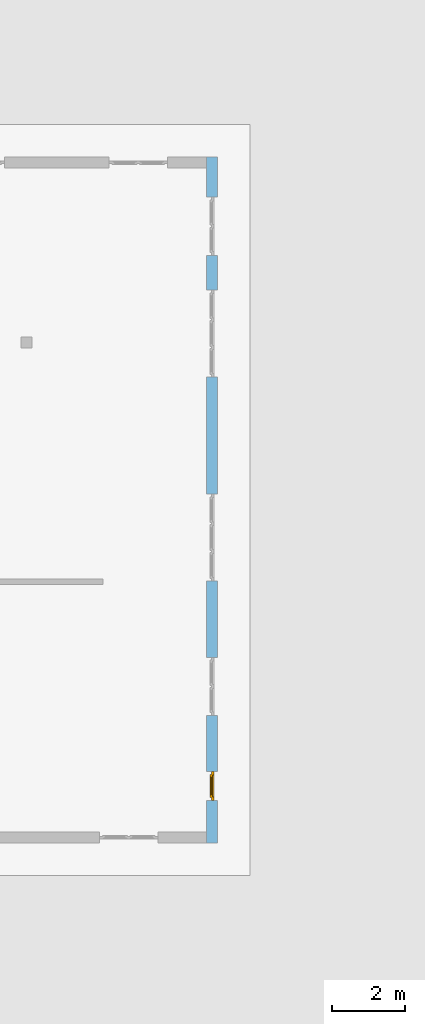
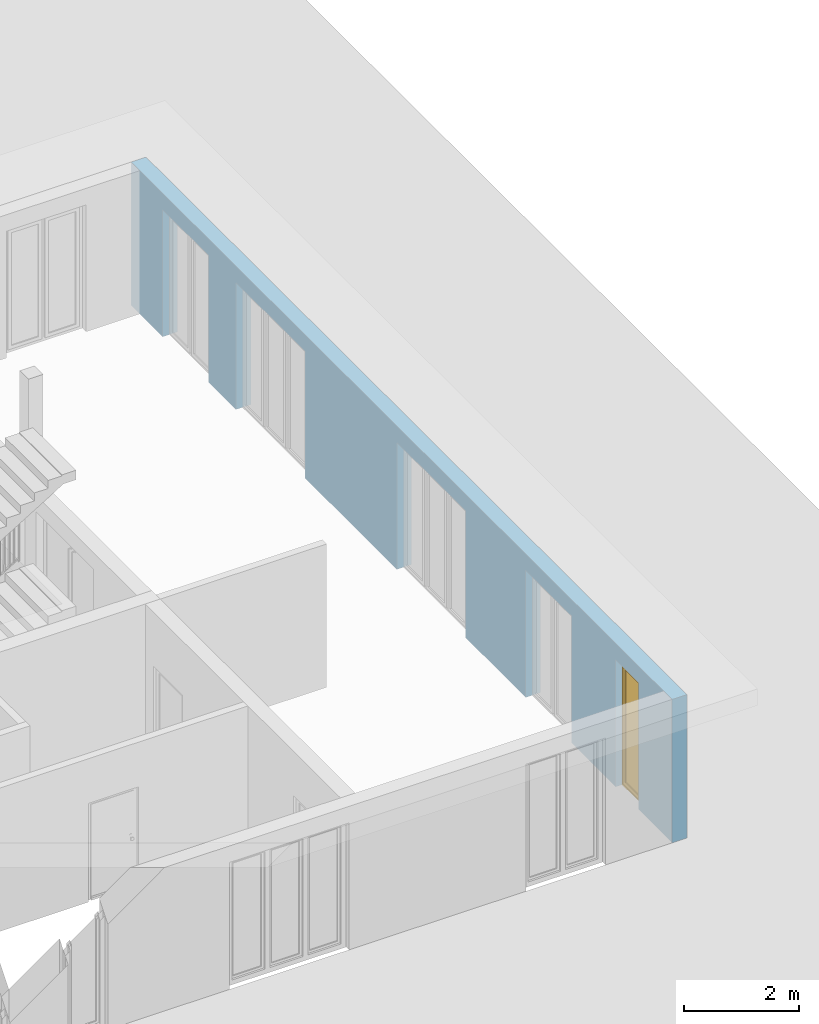
# One storey, part 14 of 23: 1 window, 5 openings, plus 1 element that does not belong to this part.
"""IFC4 building model written with IfcOpenShell, lengths in metres."""

from ifc_helpers import new_model, entity, si_unit, converted_unit, derived_unit, direction, frame, origin_with_axes, place, context, subcontext, project, spatial, polygons, source, transform, mapped, material, type_object, element, fill, save


model = new_model("IFC4")

# Units and contexts
model_context = context("Model", 3, precision=1e-05, world=origin_with_axes(), true_north=direction((0.0, 1.0)))
body_context = subcontext(model_context, "Body", "Model", "MODEL_VIEW")
ifc_project = project(units=[si_unit("LENGTHUNIT", "METRE"), si_unit("AREAUNIT", "SQUARE_METRE"), si_unit("VOLUMEUNIT", "CUBIC_METRE"), converted_unit("PLANEANGLEUNIT", "DEGREE", entity("IfcPlaneAngleMeasure", 0.0174532925199), si_unit("PLANEANGLEUNIT", "RADIAN"), dimensions=[0, 0, 0, 0, 0, 0, 0]), converted_unit("TIMEUNIT", "Year", entity("IfcTimeMeasure", 31556926.0), si_unit("TIMEUNIT", "SECOND"), dimensions=[0, 0, 1, 0, 0, 0, 0]), si_unit("MASSUNIT", "GRAM", prefix="KILO"), si_unit("THERMODYNAMICTEMPERATUREUNIT", "DEGREE_CELSIUS"), si_unit("LUMINOUSINTENSITYUNIT", "LUMEN"), si_unit("ENERGYUNIT", "JOULE", prefix="MEGA"), derived_unit("THERMALCONDUCTANCEUNIT", [(si_unit("POWERUNIT", "WATT"), 1), (si_unit("LENGTHUNIT", "METRE"), -1), (si_unit("THERMODYNAMICTEMPERATUREUNIT", "KELVIN"), -1)]), derived_unit("SPECIFICHEATCAPACITYUNIT", [(si_unit("ENERGYUNIT", "JOULE"), 1), (si_unit("MASSUNIT", "GRAM", prefix="KILO"), -1), (si_unit("THERMODYNAMICTEMPERATUREUNIT", "KELVIN"), -1)]), derived_unit("MASSDENSITYUNIT", [(si_unit("MASSUNIT", "GRAM", prefix="KILO"), 1), (si_unit("VOLUMEUNIT", "CUBIC_METRE"), -1)])], contexts=[model_context])

# Site, building, storey
site_placement = place(None, origin_with_axes())
site = spatial("IfcSite", under=ifc_project, at=site_placement, CompositionType="ELEMENT")
building_placement = place(site_placement, origin_with_axes())
building = spatial("IfcBuilding", under=site, at=building_placement, CompositionType="ELEMENT")
storey_placement = place(building_placement, origin_with_axes())
storey = spatial("IfcBuildingStorey", under=building, at=storey_placement, Name="0. Geschoss", CompositionType="ELEMENT", Elevation=0.0)

# Wall, openings, window
ifc_material = material()
wall_type = type_object("IfcWallType", Name="300", PredefinedType="NOTDEFINED")
wall_placement = place(storey_placement, frame((9.3378006196, -9.92881223104, 0.0), z_axis=(0.0, 0.0, 1.0), x_axis=(0.0, 1.0, 0.0)))
wall = element("IfcWall", 1, at=wall_placement, inside=storey, type_object=wall_type, material=ifc_material, Name="Wand-001", PredefinedType="NOTDEFINED", context=body_context, shape_type="Tessellation", body=[
    polygons([(1.16441876325, 0.1, 2.7), (1.96441876325, 0.1, 2.7), (1.96441876325, 0.0, 2.7), (1.16441876325, 0.0, 2.7), (1.16441876325, 0.3, 2.7), (1.96441876325, 0.3, 2.7), (1.96441876325, 0.1, 0.0), (1.96441876325, 0.0, 0.0), (18.85, 0.0, 3.05), (0.0, 0.0, 3.05), (0.0, 0.0, 0.0), (1.16441876325, 0.0, 0.0), (3.5, 0.0, 0.0), (3.5, 0.0, 2.7), (5.1, 0.0, 2.7), (5.1, 0.0, 0.0), (7.1921181063, 0.0, 0.0), (7.1921181063, 0.0, 2.7), (9.5921181063, 0.0, 2.7), (9.5921181063, 0.0, 0.0), (12.8, 0.0, 0.0), (12.8, 0.0, 2.7), (15.2, 0.0, 2.7), (15.2, 0.0, 0.0), (16.15, 0.0, 0.0), (16.15, 0.0, 2.7), (17.75, 0.0, 2.7), (17.75, 0.0, 0.0), (18.85, 0.0, 0.0), (1.16441876325, 0.1, 0.0), (1.16441876325, 0.3, 0.0), (0.0, 0.3, 0.0), (0.0, 0.3, 3.05), (18.85, 0.3, 3.05), (18.85, 0.3, 0.0), (17.75, 0.3, 0.0), (17.75, 0.3, 2.7), (16.15, 0.3, 2.7), (16.15, 0.3, 0.0), (15.2, 0.3, 0.0), (15.2, 0.3, 2.7), (12.8, 0.3, 2.7), (12.8, 0.3, 0.0), (9.5921181063, 0.3, 0.0), (9.5921181063, 0.3, 2.7), (7.1921181063, 0.3, 2.7), (7.1921181063, 0.3, 0.0), (5.1, 0.3, 0.0), (5.1, 0.3, 2.7), (3.5, 0.3, 2.7), (3.5, 0.3, 0.0), (1.96441876325, 0.3, 0.0), (3.5, 0.1, 0.0), (3.5, 0.1, 2.7), (5.1, 0.1, 2.7), (5.1, 0.1, 0.0), (7.1921181063, 0.1, 0.0), (7.1921181063, 0.1, 2.7), (9.5921181063, 0.1, 2.7), (9.5921181063, 0.1, 0.0), (12.8, 0.1, 0.0), (12.8, 0.1, 2.7), (15.2, 0.1, 2.7), (15.2, 0.1, 0.0), (16.15, 0.1, 0.0), (16.15, 0.1, 2.7), (17.75, 0.1, 2.7), (17.75, 0.1, 0.0)], [[[1, 2, 3, 4]], [[2, 1, 5, 6]], [[2, 7, 8, 3]], [[9, 10, 11, 12, 4, 3, 8, 13, 14, 15, 16, 17, 18, 19, 20, 21, 22, 23, 24, 25, 26, 27, 28, 29]], [[30, 1, 4, 12]], [[1, 30, 31, 5]], [[5, 31, 32, 33, 34, 35, 36, 37, 38, 39, 40, 41, 42, 43, 44, 45, 46, 47, 48, 49, 50, 51, 52, 6]], [[7, 2, 6, 52]], [[7, 52, 51, 53, 13, 8]], [[9, 34, 33, 10]], [[33, 32, 11, 10]], [[31, 30, 12, 11, 32]], [[14, 13, 53, 54]], [[15, 14, 54, 55]], [[16, 15, 55, 56]], [[56, 48, 47, 57, 17, 16]], [[57, 58, 18, 17]], [[58, 59, 19, 18]], [[59, 60, 20, 19]], [[60, 44, 43, 61, 21, 20]], [[22, 21, 61, 62]], [[23, 22, 62, 63]], [[24, 23, 63, 64]], [[64, 40, 39, 65, 25, 24]], [[65, 66, 26, 25]], [[66, 67, 27, 26]], [[67, 68, 28, 27]], [[36, 35, 29, 28, 68]], [[9, 29, 35, 34]], [[68, 67, 37, 36]], [[67, 66, 38, 37]], [[66, 65, 39, 38]], [[41, 40, 64, 63]], [[42, 41, 63, 62]], [[43, 42, 62, 61]], [[60, 59, 45, 44]], [[59, 58, 46, 45]], [[58, 57, 47, 46]], [[49, 48, 56, 55]], [[50, 49, 55, 54]], [[51, 50, 54, 53]]], closed=True),
])
opening_1_placement = place(wall_placement, frame((16.95, 0.0, 0.0), z_axis=(0.0, 0.0, 1.0), x_axis=(1.0, 0.0, 0.0)))
element("IfcOpeningElement", 2, at=opening_1_placement, cuts=wall, Name="Fenster-001", context=body_context, identifier="Reference", shape_type="Tessellation", body=[
    polygons([(0.8, 0.1, 0.0), (0.8, 0.1, 2.7), (0.8, -0.000999999999999, 2.7), (0.8, -0.000999999999999, 0.0), (0.8, 0.301, 0.0), (0.8, 0.301, 2.7), (-0.8, 0.1, 2.7), (-0.8, -0.000999999999999, 2.7), (-0.8, 0.301, 2.7), (-0.8, -0.000999999999999, 0.0), (-0.8, 0.1, 0.0), (-0.8, 0.301, 0.0)], [[[1, 2, 3, 4]], [[2, 1, 5, 6]], [[7, 8, 3, 2, 6, 9]], [[8, 10, 4, 3]], [[1, 4, 10, 11, 12, 5]], [[6, 5, 12, 9]], [[7, 11, 10, 8]], [[11, 7, 9, 12]]], closed=True),
])
opening_2_placement = place(wall_placement, frame((14.0, 0.0, 0.0), z_axis=(0.0, 0.0, 1.0), x_axis=(1.0, 0.0, 0.0)))
element("IfcOpeningElement", 3, at=opening_2_placement, cuts=wall, Name="Fenster-002", context=body_context, identifier="Reference", shape_type="Tessellation", body=[
    polygons([(1.2, 0.1, 0.0), (1.2, 0.1, 2.7), (1.2, -0.000999999999999, 2.7), (1.2, -0.000999999999999, 0.0), (1.2, 0.301, 0.0), (1.2, 0.301, 2.7), (-1.2, 0.1, 2.7), (-1.2, -0.000999999999999, 2.7), (-1.2, 0.301, 2.7), (-1.2, -0.000999999999999, 0.0), (-1.2, 0.1, 0.0), (-1.2, 0.301, 0.0)], [[[1, 2, 3, 4]], [[2, 1, 5, 6]], [[7, 8, 3, 2, 6, 9]], [[8, 10, 4, 3]], [[1, 4, 10, 11, 12, 5]], [[6, 5, 12, 9]], [[7, 11, 10, 8]], [[11, 7, 9, 12]]], closed=True),
])
opening_3_placement = place(wall_placement, frame((8.3921181063, 0.0, 0.0), z_axis=(0.0, 0.0, 1.0), x_axis=(1.0, 0.0, 0.0)))
element("IfcOpeningElement", 4, at=opening_3_placement, cuts=wall, Name="Fenster-002", context=body_context, identifier="Reference", shape_type="Tessellation", body=[
    polygons([(1.2, 0.1, 0.0), (1.2, 0.1, 2.7), (1.2, -0.000999999999999, 2.7), (1.2, -0.000999999999999, 0.0), (1.2, 0.301, 0.0), (1.2, 0.301, 2.7), (-1.2, 0.1, 2.7), (-1.2, -0.000999999999999, 2.7), (-1.2, 0.301, 2.7), (-1.2, -0.000999999999999, 0.0), (-1.2, 0.1, 0.0), (-1.2, 0.301, 0.0)], [[[1, 2, 3, 4]], [[2, 1, 5, 6]], [[7, 8, 3, 2, 6, 9]], [[8, 10, 4, 3]], [[1, 4, 10, 11, 12, 5]], [[6, 5, 12, 9]], [[7, 11, 10, 8]], [[11, 7, 9, 12]]], closed=True),
])
opening_4_placement = place(wall_placement, frame((4.3, 0.0, 0.0), z_axis=(0.0, 0.0, 1.0), x_axis=(1.0, 0.0, 0.0)))
element("IfcOpeningElement", 5, at=opening_4_placement, cuts=wall, Name="Fenster-001", context=body_context, identifier="Reference", shape_type="Tessellation", body=[
    polygons([(0.8, 0.1, 0.0), (0.8, 0.1, 2.7), (0.8, -0.000999999999999, 2.7), (0.8, -0.000999999999999, 0.0), (0.8, 0.301, 0.0), (0.8, 0.301, 2.7), (-0.8, 0.1, 2.7), (-0.8, -0.000999999999999, 2.7), (-0.8, 0.301, 2.7), (-0.8, -0.000999999999999, 0.0), (-0.8, 0.1, 0.0), (-0.8, 0.301, 0.0)], [[[1, 2, 3, 4]], [[2, 1, 5, 6]], [[7, 8, 3, 2, 6, 9]], [[8, 10, 4, 3]], [[1, 4, 10, 11, 12, 5]], [[6, 5, 12, 9]], [[7, 11, 10, 8]], [[11, 7, 9, 12]]], closed=True),
])
opening_5_placement = place(wall_placement, frame((1.56441876325, 0.0, 0.0), z_axis=(0.0, 0.0, 1.0), x_axis=(1.0, 0.0, 0.0)))
opening_5 = element("IfcOpeningElement", 6, at=opening_5_placement, cuts=wall, Name="Fenster-003", context=body_context, identifier="Reference", shape_type="Tessellation", body=[
    polygons([(0.4, 0.1, 0.0), (0.4, 0.1, 2.7), (0.4, -0.000999999999999, 2.7), (0.4, -0.000999999999999, 0.0), (0.4, 0.301, 0.0), (0.4, 0.301, 2.7), (-0.4, 0.1, 2.7), (-0.4, -0.000999999999999, 2.7), (-0.4, 0.301, 2.7), (-0.4, -0.000999999999999, 0.0), (-0.4, 0.1, 0.0), (-0.4, 0.301, 0.0)], [[[1, 2, 3, 4]], [[2, 1, 5, 6]], [[7, 8, 3, 2, 6, 9]], [[8, 10, 4, 3]], [[1, 4, 10, 11, 12, 5]], [[6, 5, 12, 9]], [[7, 11, 10, 8]], [[11, 7, 9, 12]]], closed=True),
])
window_type = type_object("IfcWindowType", Name="1-26", PartitioningType="SINGLE_PANEL", PredefinedType="WINDOW")
shared_shape = source(origin_with_axes(), body_context, "Body", "Tessellation", [
    polygons([(0.4, -0.07, 0.0), (0.3, -0.07, 0.1), (0.3, 0.0, 0.1), (0.4, 0.0, 0.0), (0.4, -0.07, 2.7), (0.3, -0.07, 2.6), (0.3, 0.0, 2.6), (0.4, 0.0, 2.7)], [[[1, 2, 3, 4]], [[1, 5, 6, 2]], [[2, 6, 7, 3]], [[4, 3, 7, 8]], [[5, 1, 4, 8]], [[6, 5, 8, 7]]], closed=True),
    polygons([(-0.4, -0.07, 0.0), (-0.4, -0.07, 2.7), (-0.4, 0.0, 2.7), (-0.4, 0.0, 0.0), (-0.3, -0.07, 0.1), (-0.3, -0.07, 2.6), (-0.3, 0.0, 2.6), (-0.3, 0.0, 0.1)], [[[1, 2, 3, 4]], [[1, 5, 6, 2]], [[2, 6, 7, 3]], [[4, 3, 7, 8]], [[5, 1, 4, 8]], [[6, 5, 8, 7]]], closed=True),
    polygons([(0.4, -0.07, 0.0), (-0.4, -0.07, 0.0), (-0.4, 0.0, 0.0), (0.4, 0.0, 0.0), (0.3, -0.07, 0.1), (0.0, -0.07, 0.1), (-0.3, -0.07, 0.1), (-0.3, 0.0, 0.1), (0.0, 0.0, 0.1), (0.3, 0.0, 0.1)], [[[1, 2, 3, 4]], [[1, 5, 6, 7, 2]], [[2, 7, 8, 3]], [[4, 3, 8, 9, 10]], [[5, 1, 4, 10]], [[6, 5, 10, 9]], [[7, 6, 9, 8]]], closed=True),
    polygons([(0.4, -0.07, 2.7), (0.3, -0.07, 2.6), (0.3, 0.0, 2.6), (0.4, 0.0, 2.7), (-0.4, -0.07, 2.7), (-0.3, -0.07, 2.6), (0.0, -0.07, 2.6), (0.0, 0.0, 2.6), (-0.3, 0.0, 2.6), (-0.4, 0.0, 2.7)], [[[1, 2, 3, 4]], [[1, 5, 6, 7, 2]], [[2, 7, 8, 3]], [[4, 3, 8, 9, 10]], [[5, 1, 4, 10]], [[6, 5, 10, 9]], [[7, 6, 9, 8]]], closed=True),
    polygons([(0.32, 0.0, 0.08), (0.25, 0.0, 0.15), (0.25, 0.03, 0.15), (0.32, 0.03, 0.08), (0.32, 0.0, 2.62), (0.25, 0.0, 2.55), (0.25, 0.03, 2.55), (0.32, 0.03, 2.62)], [[[1, 2, 3, 4]], [[1, 5, 6, 2]], [[2, 6, 7, 3]], [[4, 3, 7, 8]], [[5, 1, 4, 8]], [[6, 5, 8, 7]]], closed=True),
    polygons([(-0.32, 0.0, 0.08), (-0.32, 0.03, 0.08), (-0.25, 0.03, 0.15), (-0.25, 0.0, 0.15), (-0.32, 0.0, 2.62), (-0.32, 0.03, 2.62), (-0.25, 0.03, 2.55), (-0.25, 0.0, 2.55)], [[[1, 2, 3, 4]], [[5, 6, 2, 1]], [[2, 6, 7, 3]], [[4, 3, 7, 8]], [[1, 4, 8, 5]], [[8, 7, 6, 5]]], closed=True),
    polygons([(0.32, 0.0, 0.08), (-0.32, 0.0, 0.08), (-0.32, 0.03, 0.08), (0.32, 0.03, 0.08), (0.25, 0.0, 0.15), (-0.25, 0.0, 0.15), (-0.25, 0.03, 0.15), (0.25, 0.03, 0.15)], [[[1, 2, 3, 4]], [[1, 5, 6, 2]], [[2, 6, 7, 3]], [[4, 3, 7, 8]], [[5, 1, 4, 8]], [[6, 5, 8, 7]]], closed=True),
    polygons([(0.32, 0.0, 2.62), (0.32, 0.03, 2.62), (-0.32, 0.03, 2.62), (-0.32, 0.0, 2.62), (0.25, 0.0, 2.55), (0.25, 0.03, 2.55), (-0.25, 0.03, 2.55), (-0.25, 0.0, 2.55)], [[[1, 2, 3, 4]], [[5, 6, 2, 1]], [[2, 6, 7, 3]], [[4, 3, 7, 8]], [[1, 4, 8, 5]], [[8, 7, 6, 5]]], closed=True),
    polygons([(0.3, -0.03, 0.1), (0.25, -0.03, 0.15), (0.25, 0.0, 0.15), (0.3, 0.0, 0.1), (0.3, -0.03, 2.6), (0.25, -0.03, 2.55), (0.25, 0.0, 2.55), (0.3, 0.0, 2.6)], [[[1, 2, 3, 4]], [[1, 5, 6, 2]], [[2, 6, 7, 3]], [[4, 3, 7, 8]], [[5, 1, 4, 8]], [[6, 5, 8, 7]]], closed=True),
    polygons([(-0.3, -0.03, 0.1), (-0.3, 0.0, 0.1), (-0.25, 0.0, 0.15), (-0.25, -0.03, 0.15), (-0.3, -0.03, 2.6), (-0.3, 0.0, 2.6), (-0.25, 0.0, 2.55), (-0.25, -0.03, 2.55)], [[[1, 2, 3, 4]], [[5, 6, 2, 1]], [[2, 6, 7, 3]], [[4, 3, 7, 8]], [[1, 4, 8, 5]], [[8, 7, 6, 5]]], closed=True),
    polygons([(0.3, -0.03, 0.1), (-0.3, -0.03, 0.1), (-0.3, 0.0, 0.1), (0.3, 0.0, 0.1), (0.25, -0.03, 0.15), (-0.25, -0.03, 0.15), (-0.25, 0.0, 0.15), (0.25, 0.0, 0.15)], [[[1, 2, 3, 4]], [[1, 5, 6, 2]], [[2, 6, 7, 3]], [[4, 3, 7, 8]], [[5, 1, 4, 8]], [[6, 5, 8, 7]]], closed=True),
    polygons([(0.3, -0.03, 2.6), (0.3, 0.0, 2.6), (-0.3, 0.0, 2.6), (-0.3, -0.03, 2.6), (0.25, -0.03, 2.55), (0.25, 0.0, 2.55), (-0.25, 0.0, 2.55), (-0.25, -0.03, 2.55)], [[[1, 2, 3, 4]], [[5, 6, 2, 1]], [[2, 6, 7, 3]], [[4, 3, 7, 8]], [[1, 4, 8, 5]], [[8, 7, 6, 5]]], closed=True),
    polygons([(0.25, -0.005, 0.15), (-0.25, -0.005, 0.15), (-0.25, 0.005, 0.15), (0.25, 0.005, 0.15), (0.25, -0.005, 2.55), (-0.25, -0.005, 2.55), (-0.25, 0.005, 2.55), (0.25, 0.005, 2.55)], [[[1, 2, 3, 4]], [[1, 5, 6, 2]], [[2, 6, 7, 3]], [[4, 3, 7, 8]], [[5, 1, 4, 8]], [[6, 5, 8, 7]]], closed=True),
])
window_placement = place(opening_5_placement, frame((-0.4, 0.0, 0.0), z_axis=(0.0, 0.0, 1.0), x_axis=(1.0, 0.0, 0.0)))
window = element("IfcWindow", 7, at=window_placement, inside=storey, type_object=window_type, Name="Fenster-003", OverallHeight=2.7, OverallWidth=0.8, PredefinedType="WINDOW", context=body_context, shape_type="MappedRepresentation", body=[
    mapped(shared_shape, transform((0.4, 0.17, 0.0))),
])
fill(opening_5, window)

save(model, "model.ifc")
